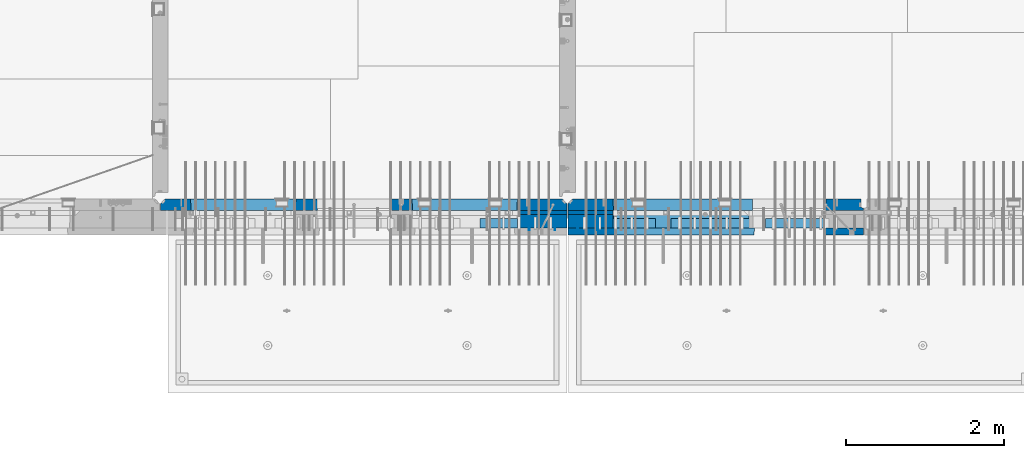
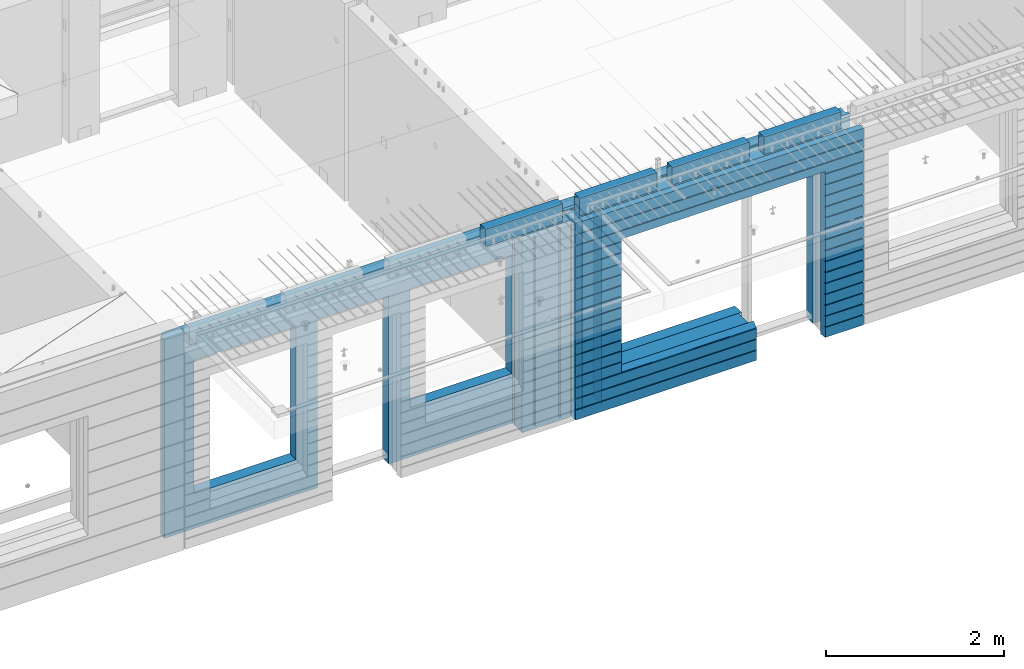
# One storey, part 221 of 334: 16 walls, 8 elements without a shape of their own.
"""IFC2X3 building model written with IfcOpenShell, lengths in millimetres."""

from ifc_helpers import new_model, si_unit, frame, origin_with_axes, place, context, subcontext, project, spatial, faceted_brep, material, type_object, element, aggregate, save


model = new_model("IFC2X3")

# Units and contexts
model_context = context("Model", 3, precision=1e-05, world=origin_with_axes())
body_context = subcontext(model_context, "Body", "Model", "MODEL_VIEW")
ifc_project = project(units=[si_unit("LENGTHUNIT", "METRE", prefix="MILLI"), si_unit("AREAUNIT", "SQUARE_METRE"), si_unit("VOLUMEUNIT", "CUBIC_METRE"), si_unit("MASSUNIT", "GRAM", prefix="KILO"), si_unit("TIMEUNIT", "SECOND"), si_unit("PLANEANGLEUNIT", "RADIAN"), si_unit("SOLIDANGLEUNIT", "STERADIAN"), si_unit("THERMODYNAMICTEMPERATUREUNIT", "DEGREE_CELSIUS"), si_unit("LUMINOUSINTENSITYUNIT", "LUMEN")], contexts=[model_context])

# Site, building, storey
site_placement = place(None, origin_with_axes())
site = spatial("IfcSite", under=ifc_project, at=site_placement, CompositionType="ELEMENT")
building_placement = place(site_placement, origin_with_axes())
building = spatial("IfcBuilding", under=site, at=building_placement, CompositionType="ELEMENT")
storey_placement = place(building_placement, origin_with_axes())
storey = spatial("IfcBuildingStorey", under=building, at=storey_placement, Name="3", CompositionType="ELEMENT", Elevation=0.0)

# Assembly, wall
assembly_1_placement = place(storey_placement, origin_with_axes())
assembly_1 = element("IfcElementAssembly", 1, at=assembly_1_placement, inside=storey, AssemblyPlace="NOTDEFINED", PredefinedType="REINFORCEMENT_UNIT")
ifc_material_1 = material(Name="Undefined")
wall_type_1 = type_object("IfcWallType", PredefinedType="NOTDEFINED")
wall_1_placement = place(assembly_1_placement, frame((21325.0, 7780.0, 89115.0), z_axis=(0.0, 0.0, 1.0), x_axis=(0.0, -1.0, 0.0)))
wall_1 = element("IfcWall", 2, at=wall_1_placement, type_object=wall_type_1, material=ifc_material_1, Name="(PD)", context=body_context, shape_type="Brep", body=[
    faceted_brep([(0.0, 5.0, -1300.0), (0.0, 5.0, 1300.0), (180.0, 5.0, 1300.0), (180.0, 5.0, -1300.0), (0.0, -5.0, 1300.0), (180.0, -5.0, 1300.0), (0.0, -5.0, -1300.0), (180.0, -5.0, -1300.0)], [[[0, 1, 2, 3]], [[1, 4, 5, 2]], [[4, 6, 7, 5]], [[6, 0, 3, 7]], [[5, 7, 3, 2]], [[6, 4, 1, 0]]]),
])

# Assembly, walls
assembly_2_placement = place(storey_placement, origin_with_axes())
assembly_2 = element("IfcElementAssembly", 3, at=assembly_2_placement, inside=storey, AssemblyPlace="NOTDEFINED", PredefinedType="REINFORCEMENT_UNIT")
wall_2_placement = place(assembly_2_placement, frame((22190.0, 7780.0, 89115.0), z_axis=(0.0, 0.0, 1.0), x_axis=(0.0, -1.0, 0.0)))
wall_2 = element("IfcWall", 4, at=wall_2_placement, type_object=wall_type_1, material=ifc_material_1, Name="(PD)", context=body_context, shape_type="Brep", body=[
    faceted_brep([(0.0, 5.0, -1300.0), (0.0, 5.0, 1300.0), (180.0, 5.0, 1300.0), (180.0, 5.0, -1300.0), (0.0, -5.0, 1300.0), (180.0, -5.0, 1300.0), (0.0, -5.0, -1300.0), (180.0, -5.0, -1300.0)], [[[0, 1, 2, 3]], [[1, 4, 5, 2]], [[4, 6, 7, 5]], [[6, 0, 3, 7]], [[5, 7, 3, 2]], [[6, 4, 1, 0]]]),
])
wall_3_placement = place(assembly_2_placement, frame((21940.0, 7780.0, 89115.0), z_axis=(0.0, 0.0, 1.0), x_axis=(0.0, -1.0, 0.0)))
wall_3 = element("IfcWall", 5, at=wall_3_placement, type_object=wall_type_1, material=ifc_material_1, Name="(PD)", context=body_context, shape_type="Brep", body=[
    faceted_brep([(0.0, 5.0, -1300.0), (0.0, 5.0, 1300.0), (180.0, 5.0, 1300.0), (180.0, 5.0, -1300.0), (0.0, -5.0, 1300.0), (180.0, -5.0, 1300.0), (0.0, -5.0, -1300.0), (180.0, -5.0, -1300.0)], [[[0, 1, 2, 3]], [[1, 4, 5, 2]], [[4, 6, 7, 5]], [[6, 0, 3, 7]], [[5, 7, 3, 2]], [[6, 4, 1, 0]]]),
])

# Wall
wall_4_placement = place(assembly_1_placement, frame((21650.0, 7780.0, 89115.0), z_axis=(0.0, 0.0, 1.0), x_axis=(0.0, -1.0, 0.0)))
wall_4 = element("IfcWall", 6, at=wall_4_placement, type_object=wall_type_1, material=ifc_material_1, Name="(PD)", context=body_context, shape_type="Brep", body=[
    faceted_brep([(0.0, 5.0, -1300.0), (0.0, 5.0, 1300.0), (180.0, 5.0, 1300.0), (180.0, 5.0, -1300.0), (0.0, -5.0, 1300.0), (180.0, -5.0, 1300.0), (0.0, -5.0, -1300.0), (180.0, -5.0, -1300.0)], [[[0, 1, 2, 3]], [[1, 4, 5, 2]], [[4, 6, 7, 5]], [[6, 0, 3, 7]], [[5, 7, 3, 2]], [[6, 4, 1, 0]]]),
])

# Assemblies, wall
assembly_3_placement = place(storey_placement, origin_with_axes())
assembly_3 = element("IfcElementAssembly", 7, at=assembly_3_placement, inside=storey, AssemblyPlace="NOTDEFINED", PredefinedType="REINFORCEMENT_UNIT")
assembly_4_placement = place(assembly_3_placement, origin_with_axes())
assembly_4 = element("IfcElementAssembly", 8, at=assembly_4_placement, Name="Steel Assembly", AssemblyPlace="NOTDEFINED", PredefinedType="NOTDEFINED")
aggregate(assembly_3, [assembly_4])
ifc_material_2 = material()
wall_type_2 = type_object("IfcWallType", PredefinedType="NOTDEFINED")
wall_5_placement = place(assembly_4_placement, frame((20699.9998568133, 7690.00021946163, 90590.0), z_axis=(0.0, 0.0, 1.0), x_axis=(1.0, 0.0, 0.0)))
wall_5 = element("IfcWall", 9, at=wall_5_placement, type_object=wall_type_2, material=ifc_material_2, context=body_context, shape_type="Brep", body=[
    faceted_brep([(0.0, 60.0, -120.0), (0.0, 60.0, 120.0), (1000.0, 60.0, 120.0), (1000.0, 60.0, -120.0), (0.0, -60.0, 120.0), (1000.0, -60.0, 120.0), (0.0, -60.0, -120.0), (1000.0, -60.0, -120.0)], [[[0, 1, 2, 3]], [[1, 4, 5, 2]], [[4, 6, 7, 5]], [[6, 0, 3, 7]], [[5, 7, 3, 2]], [[6, 4, 1, 0]]]),
])
aggregate(assembly_4, [wall_5])

# Assemblies, walls
assembly_5_placement = place(storey_placement, origin_with_axes())
assembly_5 = element("IfcElementAssembly", 10, at=assembly_5_placement, inside=storey, AssemblyPlace="NOTDEFINED", PredefinedType="REINFORCEMENT_UNIT")
assembly_6_placement = place(assembly_5_placement, origin_with_axes())
assembly_6 = element("IfcElementAssembly", 11, at=assembly_6_placement, Name="Steel Assembly", AssemblyPlace="NOTDEFINED", PredefinedType="NOTDEFINED")
wall_6_placement = place(assembly_6_placement, frame((24309.9998568133, 7690.00021946163, 90590.0), z_axis=(0.0, 0.0, 1.0), x_axis=(1.0, 0.0, 0.0)))
wall_6 = element("IfcWall", 12, at=wall_6_placement, type_object=wall_type_2, material=ifc_material_2, context=body_context, shape_type="Brep", body=[
    faceted_brep([(0.0, 60.0, -120.0), (0.0, 60.0, 120.0), (1000.0, 60.0, 120.0), (1000.0, 60.0, -120.0), (0.0, -60.0, 120.0), (1000.0, -60.0, 120.0), (0.0, -60.0, -120.0), (1000.0, -60.0, -120.0)], [[[0, 1, 2, 3]], [[1, 4, 5, 2]], [[4, 6, 7, 5]], [[6, 0, 3, 7]], [[5, 7, 3, 2]], [[6, 4, 1, 0]]]),
])
aggregate(assembly_6, [wall_6])
assembly_7_placement = place(assembly_5_placement, origin_with_axes())
assembly_7 = element("IfcElementAssembly", 13, at=assembly_7_placement, Name="Steel Assembly", AssemblyPlace="NOTDEFINED", PredefinedType="NOTDEFINED")
wall_7_placement = place(assembly_7_placement, frame((23119.9998568133, 7690.00021946163, 90590.0), z_axis=(0.0, 0.0, 1.0), x_axis=(1.0, 0.0, 0.0)))
wall_7 = element("IfcWall", 14, at=wall_7_placement, type_object=wall_type_2, material=ifc_material_2, context=body_context, shape_type="Brep", body=[
    faceted_brep([(0.0, 60.0, -120.0), (0.0, 60.0, 120.0), (1000.0, 60.0, 120.0), (1000.0, 60.0, -120.0), (0.0, -60.0, 120.0), (1000.0, -60.0, 120.0), (0.0, -60.0, -120.0), (1000.0, -60.0, -120.0)], [[[0, 1, 2, 3]], [[1, 4, 5, 2]], [[4, 6, 7, 5]], [[6, 0, 3, 7]], [[5, 7, 3, 2]], [[6, 4, 1, 0]]]),
])
aggregate(assembly_7, [wall_7])
assembly_8_placement = place(assembly_5_placement, origin_with_axes())
assembly_8 = element("IfcElementAssembly", 15, at=assembly_8_placement, Name="Steel Assembly", AssemblyPlace="NOTDEFINED", PredefinedType="NOTDEFINED")
aggregate(assembly_5, [assembly_8, assembly_7, assembly_6])
wall_8_placement = place(assembly_8_placement, frame((21919.9998568133, 7690.00021946163, 90590.0), z_axis=(0.0, 0.0, 1.0), x_axis=(1.0, 0.0, 0.0)))
wall_8 = element("IfcWall", 16, at=wall_8_placement, type_object=wall_type_2, material=ifc_material_2, context=body_context, shape_type="Brep", body=[
    faceted_brep([(0.0, 60.0, -120.0), (0.0, 60.0, 120.0), (1000.0, 60.0, 120.0), (1000.0, 60.0, -120.0), (0.0, -60.0, 120.0), (1000.0, -60.0, 120.0), (0.0, -60.0, -120.0), (1000.0, -60.0, -120.0)], [[[0, 1, 2, 3]], [[1, 4, 5, 2]], [[4, 6, 7, 5]], [[6, 0, 3, 7]], [[5, 7, 3, 2]], [[6, 4, 1, 0]]]),
])
aggregate(assembly_8, [wall_8])

# Wall
ifc_material_3 = material(Name="CONCRETE/C35/45")
wall_type_3 = type_object("IfcWallType", PredefinedType="NOTDEFINED")
wall_9_placement = place(assembly_2_placement, frame((25550.0, 7925.0, 89112.5), z_axis=(0.0, 0.0, 1.0), x_axis=(-1.0, 3.00000001838171e-08, 0.0)))
wall_9 = element("IfcWall", 17, at=wall_9_placement, type_object=wall_type_3, material=ifc_material_3, context=body_context, shape_type="Brep", body=[
    faceted_brep([(0.0, 75.0, 1357.5), (0.0, 75.0, -1357.5), (0.0, 45.0, -1357.5), (0.0, 45.0, 1357.5), (475.000517197066, -75.0, -1357.5), (478.846671043222, 75.0, -1357.5), (478.846671043219, 75.0, 948.653846153844), (475.000517197066, -75.0, 952.5), (32.5, -75.0, -1357.5), (32.5, 32.0, -1357.5), (32.5, -75.0, 1357.5), (32.5, 32.0, 1357.5), (3675.0, -75.0, 1357.5), (3735.0, -15.0, 1357.5), (3735.0, 75.0, 1357.5), (3735.0, 75.0, -1357.5), (3735.0, -15.0, -1357.5), (3675.0, -75.0, -1357.5), (1405.00051719707, -75.0, -1357.5), (1401.15436335091, 75.0, -1357.5), (1405.00051719707, -75.0, -882.5), (1401.15436335091, 75.0, -878.445945945947), (1334.05403802673, 75.0, 948.653846153844), (3160.9460816706, 75.0, -878.445945945947), (3160.9460816706, 75.0, 948.445945945947), (1401.15436335091, 75.0, 948.653846153844), (1330.00013572465, -75.0, 952.5), (1405.00051719707, -75.0, 952.5), (3165.00013572465, -75.0, -882.5), (3165.00013572465, -75.0, 952.5)], [[[0, 1, 2, 3]], [[4, 5, 6, 7]], [[8, 9, 2, 1, 5, 4]], [[10, 11, 9, 8]], [[3, 2, 9, 11]], [[10, 12, 13, 14, 0, 3, 11]], [[15, 14, 13, 16]], [[12, 17, 16, 13]], [[15, 16, 17, 18, 19]], [[19, 18, 20, 21]], [[22, 6, 5, 1, 0, 14, 15, 19, 21, 23, 24, 25]], [[26, 7, 6, 22, 25, 27]], [[28, 20, 18, 17, 12, 10, 8, 4, 7, 26, 27, 29]], [[25, 24, 29, 27]], [[23, 28, 29, 24]], [[21, 20, 28, 23]]]),
])

wall_10_placement = place(assembly_1_placement, frame((21810.0, 7925.0, 89112.5), z_axis=(0.0, 0.0, 1.0), x_axis=(-1.0, 3.00000001838171e-08, 0.0)))
wall_10 = element("IfcWall", 18, at=wall_10_placement, type_object=wall_type_3, material=ifc_material_3, context=body_context, shape_type="Brep", body=[
    faceted_brep([(5145.0, 75.0, -1357.5), (5145.0, -15.0, -1357.5), (5085.0, -75.0, -1357.5), (3165.00051719707, -75.0, -1357.5), (3161.15436335092, 75.0, -1357.5), (5085.0, -75.0, 1357.5), (5145.0, -15.0, 1357.5), (5145.0, 75.0, 1357.5), (10.0, 75.0, 1357.5), (10.0, -15.0, 1357.5), (70.0, -75.0, 1357.5), (10.0, -15.0, -1357.5), (70.0, -75.0, -1357.5), (10.0, 75.0, -1357.5), (2238.84667104322, 75.0, -1357.5), (2235.00051719707, -75.0, -1357.5), (2238.84667104322, 75.0, 948.653846153844), (2235.00051719707, -75.0, 952.5), (635.00013572734, -75.0, -682.5), (639.054189781393, 75.0, -678.445945945947), (639.054189781393, 75.0, 948.445945945947), (635.00013572734, -75.0, 952.5), (1965.00013572734, -75.0, -682.5), (1960.94608167329, 75.0, -678.445945945947), (1965.00013572734, -75.0, 952.5), (1960.94608167329, 75.0, 948.445945945947), (4764.99937278789, -75.0, -882.5), (4760.94531873383, 75.0, -878.445945945947), (3439.05342684194, 75.0, -878.445945945947), (3434.99937278789, -75.0, -882.5), (3165.00051719707, -75.0, 952.5), (3434.99937278789, -75.0, 952.5), (4764.99937278789, -75.0, 952.5), (4760.94531873383, 75.0, 948.445945945947), (3439.05342684194, 75.0, 948.445945945947), (3161.15436335092, 75.0, 948.653846153844)], [[[0, 1, 2, 3, 4]], [[5, 2, 1, 6]], [[0, 7, 6, 1]], [[5, 6, 7, 8, 9, 10]], [[9, 11, 12, 10]], [[8, 13, 11, 9]], [[12, 11, 13, 14, 15]], [[15, 14, 16, 17]], [[18, 19, 20, 21]], [[22, 23, 19, 18]], [[23, 22, 24, 25]], [[21, 20, 25, 24]], [[26, 27, 28, 29]], [[3, 2, 5, 10, 12, 15, 17, 30], [26, 29, 31, 32], [22, 18, 21, 24]], [[27, 26, 32, 33]], [[31, 34, 33, 32]], [[29, 28, 34, 31]], [[13, 8, 7, 0, 4, 35, 16, 14], [27, 33, 34, 28], [23, 25, 20, 19]], [[17, 16, 35, 30]], [[4, 3, 30, 35]]]),
])

wall_type_4 = type_object("IfcWallType", PredefinedType="NOTDEFINED")
wall_11_placement = place(assembly_1_placement, frame((21800.0000381475, 7825.0, 89112.5), z_axis=(0.0, 0.0, 1.0), x_axis=(-1.0, 3.00000001838171e-08, 0.0)))
wall_11 = element("IfcWall", 19, at=wall_11_placement, type_object=wall_type_4, material=ifc_material_3, context=body_context, shape_type="Brep", body=[
    faceted_brep([(0.0, 25.0, -1357.5), (0.0, 25.0, 1357.5), (625.001908754726, 25.0, 1357.5), (625.001908754726, 25.0, -1357.5), (0.0, -25.0, 1357.5), (625.001908754726, -25.0, 1357.5), (0.0, -25.0, -1357.5), (625.001908754726, -25.0, -1357.5)], [[[0, 1, 2, 3]], [[1, 4, 5, 2]], [[4, 6, 7, 5]], [[6, 0, 3, 7]], [[5, 7, 3, 2]], [[6, 4, 1, 0]]]),
])

wall_12_placement = place(assembly_2_placement, frame((22385.0000381475, 7825.00011629906, 89112.5), z_axis=(0.0, 0.0, 1.0), x_axis=(-1.0, 3.00000001838171e-08, 0.0)))
wall_12 = element("IfcWall", 20, at=wall_12_placement, type_object=wall_type_4, material=ifc_material_3, context=body_context, shape_type="Brep", body=[
    faceted_brep([(0.0, 25.0, -1357.5), (0.0, 25.0, 1357.5), (570.001908754726, 25.0, 1357.5), (570.001908754726, 25.0, -1357.5), (0.0, -25.0, 1357.5), (570.001908754726, -25.0, 1357.5), (0.0, -25.0, -1357.5), (570.001908754726, -25.0, -1357.5)], [[[0, 1, 2, 3]], [[1, 4, 5, 2]], [[4, 6, 7, 5]], [[6, 0, 3, 7]], [[5, 7, 3, 2]], [[6, 4, 1, 0]]]),
])

ifc_material_4 = material(Name="SPU")
wall_type_5 = type_object("IfcWallType", PredefinedType="NOTDEFINED")
wall_13_placement = place(assembly_1_placement, frame((21800.0000381475, 7715.0, 89102.5), z_axis=(0.0, 0.0, 1.0), x_axis=(-1.0, 3.00000001838171e-08, 0.0)))
wall_13 = element("IfcWall", 21, at=wall_13_placement, type_object=wall_type_5, material=ifc_material_4, context=body_context, shape_type="Brep", body=[
    faceted_brep([(0.0, 85.0, -1347.5), (0.0, 85.0, 1347.5), (625.001908754726, 85.0, 1347.5), (625.001908754726, 85.0, -1347.5), (0.0, -85.0, 1347.5), (625.001908754726, -85.0, 1347.5), (0.0, -85.0, -1347.5), (625.001908754726, -85.0, -1347.5)], [[[0, 1, 2, 3]], [[1, 4, 5, 2]], [[4, 6, 7, 5]], [[6, 0, 3, 7]], [[5, 7, 3, 2]], [[6, 4, 1, 0]]]),
])

aggregate(assembly_1, [wall_13, wall_11, wall_1, wall_4, wall_10])

wall_14_placement = place(assembly_2_placement, frame((22385.0000381475, 7715.00011629906, 89102.5), z_axis=(0.0, 0.0, 1.0), x_axis=(-1.0, 3.00000001838171e-08, 0.0)))
wall_14 = element("IfcWall", 22, at=wall_14_placement, type_object=wall_type_5, material=ifc_material_4, context=body_context, shape_type="Brep", body=[
    faceted_brep([(0.0, 85.0, -1347.5), (0.0, 85.0, 1347.5), (570.001908754726, 85.0, 1347.5), (570.001908754726, 85.0, -1347.5), (0.0, -85.0, 1347.5), (570.001908754726, -85.0, 1347.5), (0.0, -85.0, -1347.5), (570.001908754726, -85.0, -1347.5)], [[[0, 1, 2, 3]], [[1, 4, 5, 2]], [[4, 6, 7, 5]], [[6, 0, 3, 7]], [[5, 7, 3, 2]], [[6, 4, 1, 0]]]),
])

ifc_material_5 = material(Name="CONCRETE/C30/37")
wall_type_6 = type_object("IfcWallType", PredefinedType="NOTDEFINED")
wall_15_placement = place(assembly_2_placement, frame((25550.0, 7587.5, 89102.5), z_axis=(0.0, 0.0, 1.0), x_axis=(-1.0, 3.00000001838171e-08, 0.0)))
wall_15 = element("IfcWall", 23, at=wall_15_placement, type_object=wall_type_6, material=ifc_material_5, context=body_context, shape_type="Brep", body=[
    faceted_brep([(3135.00013572465, 42.5, -912.000000055254), (3135.00013572465, 42.5, -912.5), (3134.8486205936, 41.2121213860491, -911.742424344731), (3735.0, 32.4999991126861, -1049.99999959956), (3735.0, 32.4999992506973, -1060.00000000076), (1383.82179161871, 32.4999992506973, -1060.00000000076), (1383.82179160247, 32.4999991126861, -1049.99999959956), (3735.0, 42.5, -1062.00000005522), (1384.99845837354, 42.5, -1062.00000005522), (3735.0, 42.5, -1198.00000011075), (1384.99845837354, 42.5, -1198.00000011075), (3735.0, 32.4999991121604, -1199.99999959957), (1383.8217916024, 32.4999991121604, -1199.99999959957), (3735.0, 32.4999992501671, -1210.00000000079), (1383.82179161864, 32.4999992501671, -1210.00000000079), (3735.0, 42.5, -1212.00000005524), (1384.99845837354, 42.5, -1212.00000005524), (3735.0, 42.5, -1347.5), (1384.99845837354, 42.5, -1347.5), (3735.0, -42.5, -1347.5), (1374.99679170687, -42.5, -1347.5), (3.63797880709171e-12, 32.4999992499725, 1039.99999999921), (3735.0, 32.4999992499725, 1039.99999999921), (3735.0, 42.5, 1037.99999994476), (0.0, 42.5, 1037.99999994476), (3.63797880709171e-12, 32.4999991119639, 1050.00000040043), (3735.0, 32.4999991119639, 1050.00000040043), (0.0, 42.5, 1051.99999988925), (3735.0, 42.5, 1051.99999988925), (0.0, 42.5, 1187.99999994476), (3735.0, 42.5, 1187.99999994476), (-3.63797880709171e-12, 32.499999249967, 1189.99999999923), (3735.0, 32.499999249967, 1189.99999999923), (-3.63797880709171e-12, 32.4999991119576, 1200.00000040043), (3735.0, 32.4999991119576, 1200.00000040043), (0.0, 42.5, 1201.99999988925), (3735.0, 42.5, 1201.99999988925), (0.0, 42.5, 1347.5), (3735.0, 42.5, 1347.5), (0.0, -42.5, 1347.5), (3735.0, -42.5, 1347.5), (3125.00013572465, -42.5, 927.5), (3125.00013572465, -42.5, -862.5), (1374.99679170687, -42.5, -862.5), (0.0, -42.5, -1347.5), (505.000125040202, -42.5, -1347.5), (505.000125040206, -42.5, 927.5), (505.000125040206, -42.5, 932.502857142856), (1370.00013572465, -42.5, 932.502857142856), (1374.99679170687, -42.5, 932.5), (3125.00013572465, -42.5, 932.5), (0.0, 42.5, -1347.5), (494.998458373539, 42.5, -1347.5), (0.0, 42.5, -1212.00000005524), (494.998458373539, 42.5, -1212.00000005524), (0.0, 32.4999992501671, -1210.00000000079), (496.175125128437, 32.4999992501671, -1210.00000000079), (0.0, 32.4999991121604, -1199.99999959957), (496.175125144673, 32.4999991121604, -1199.99999959957), (0.0, 42.5, -1198.00000011075), (494.998458373539, 42.5, -1198.00000011075), (0.0, 42.5, -1062.00000005522), (494.998458373539, 42.5, -1062.00000005522), (0.0, 32.4999992506973, -1060.00000000076), (496.175125128375, 32.4999992506973, -1060.00000000076), (0.0, 32.4999991126861, -1049.99999959956), (496.175125144611, 32.4999991126861, -1049.99999959956), (0.0, 42.5, -1048.00000011074), (494.998458373539, 42.5, -1048.00000011074), (0.0, 42.5, -912.000000055254), (494.998458373539, 42.5, -912.000000055254), (0.0, 32.4999992512376, -910.000000000786), (496.175125128309, 32.4999992512376, -910.000000000786), (0.0, 32.499999113239, -899.99999959959), (496.175125144546, 32.499999113239, -899.99999959959), (0.0, 42.5, -898.000000110769), (494.998458373539, 42.5, -898.000000110769), (0.0, 42.5, -762.000000055225), (494.998458373539, 42.5, -762.000000055225), (0.0, 32.4999992517696, -760.000000000757), (496.175125128244, 32.4999992517696, -760.000000000757), (0.0, 32.4999991137702, -749.99999959956), (496.175125144484, 32.4999991137702, -749.99999959956), (0.0, 42.5, -748.00000011074), (494.998458373539, 42.5, -748.00000011074), (0.0, 42.5, -612.000000055239), (494.998458373539, 42.5, -612.000000055239), (0.0, 32.4999992522971, -610.000000000771), (496.175125128182, 32.4999992522971, -610.000000000771), (0.0, 32.4999991143004, -599.99999959956), (496.175125144422, 32.4999991143004, -599.99999959956), (0.0, 42.5, -598.000000110755), (494.998458373539, 42.5, -598.000000110755), (0.0, 42.5, -462.000000055239), (494.998458373539, 42.5, -462.000000055239), (0.0, 32.4999992528365, -460.000000000771), (496.17512512812, 32.4999992528365, -460.000000000771), (0.0, 32.4999991148252, -449.999999599575), (496.17512514436, 32.4999991148252, -449.999999599575), (0.0, 42.5, -448.000000110755), (494.998458373539, 42.5, -448.000000110755), (0.0, 42.5, -312.000000055254), (494.998458373539, 42.5, -312.000000055254), (0.0, 32.4999992533649, -310.000000000786), (496.175125128058, 32.4999992533649, -310.000000000786), (0.0, 32.4999991153618, -299.99999959959), (496.175125144298, 32.4999991153618, -299.99999959959), (0.0, 42.5, -298.000000110769), (494.998458373539, 42.5, -298.000000110769), (0.0, 42.5, -162.000000055239), (494.998458373539, 42.5, -162.000000055239), (0.0, 32.4999992538978, -160.000000000757), (496.175125127997, 32.4999992538978, -160.000000000757), (0.0, 32.4999991158993, -149.99999959956), (496.175125144237, 32.4999991158993, -149.99999959956), (0.0, 42.5, -148.000000110755), (494.998458373539, 42.5, -148.000000110755), (0.0, 42.5, -12.0000000552391), (494.998458373539, 42.5, -12.0000000552391), (0.0, 32.4999992538942, -10.0000000007858), (496.175125127997, 32.4999992538942, -10.0000000007858), (3.63797880709171e-12, 32.4999992499852, 889.999999999229), (3.63797880709171e-12, 32.4999991119857, 900.000000400425), (496.175125144691, 32.4999991119857, 900.000000400425), (496.175125128459, 32.4999992499852, 889.999999999229), (0.0, 42.5, 887.999999944761), (494.998458373539, 42.5, 887.999999944761), (0.0, 42.5, 751.999999889245), (494.998458373539, 42.5, 751.999999889245), (0.0, 32.4999991120039, 750.00000040044), (496.175125144691, 32.4999991120039, 750.00000040044), (0.0, 32.4999992499997, 739.999999999229), (496.175125128455, 32.4999992499997, 739.999999999229), (0.0, 42.5, 737.999999944761), (494.998458373539, 42.5, 737.999999944761), (0.0, 42.5, 601.99999988926), (494.998458373539, 42.5, 601.99999988926), (0.0, 32.4999991120094, 600.00000040044), (496.175125144691, 32.4999991120094, 600.00000040044), (0.0, 32.499999250017, 589.999999999229), (496.175125128455, 32.499999250017, 589.999999999229), (0.0, 42.5, 587.999999944775), (494.998458373539, 42.5, 587.999999944775), (0.0, 42.5, 451.999999889231), (494.998458373539, 42.5, 451.999999889231), (0.0, 32.4999991120258, 450.000000400411), (496.175125144688, 32.4999991120258, 450.000000400411), (0.0, 32.4999992500289, 439.999999999214), (496.175125128451, 32.4999992500289, 439.999999999214), (0.0, 42.5, 437.999999944746), (494.998458373539, 42.5, 437.999999944746), (0.0, 42.5, 301.999999889245), (494.998458373539, 42.5, 301.999999889245), (-3.63797880709171e-12, 32.4999991120458, 300.00000040044), (496.175125144688, 32.4999991120458, 300.00000040044), (-3.63797880709171e-12, 32.4999992500416, 289.999999999229), (496.175125128451, 32.4999992500416, 289.999999999229), (0.0, 42.5, 287.999999944761), (494.998458373539, 42.5, 287.999999944761), (0.0, 42.5, 151.99999988926), (494.998458373539, 42.5, 151.99999988926), (0.0, 32.4999991120549, 150.00000040044), (496.175125144684, 32.4999991120549, 150.00000040044), (0.0, 32.4999992500552, 139.999999999229), (496.175125128448, 32.4999992500552, 139.999999999229), (0.0, 42.5, 137.999999944775), (494.998458373539, 42.5, 137.999999944775), (0.0, 42.5, 1.99999988924537), (494.998458373539, 42.5, 1.99999988924537), (0.0, 32.4999991158911, 4.00425051338971e-07), (496.175125144237, 32.4999991158911, 4.00425051338971e-07), (0.0, 42.5, 901.999999889245), (494.998458373539, 42.5, 901.999999889245), (494.998458373539, 42.5, 927.5), (505.000517197066, 42.5, 927.5), (1360.00013572465, 42.5, 927.5), (1370.00013572465, 42.5, 927.5), (1375.00051719707, 42.5, 927.5), (1384.99845837354, 42.5, 927.5), (3125.00013572465, 42.5, 927.5), (3135.00013572465, 42.5, 927.5), (3735.0, 42.5, 901.999999889245), (3135.00013572465, 42.5, 901.999999889245), (3735.0, 32.4999991119857, 900.000000400425), (3133.82366503195, 32.4999991119857, 900.000000400425), (3735.0, 32.4999992499852, 889.999999999229), (3133.82366504818, 32.4999992499852, 889.999999999229), (3735.0, 42.5, 887.999999944761), (3135.00013572465, 42.5, 887.999999944761), (3735.0, 42.5, 751.999999889245), (3135.00013572465, 42.5, 751.999999889245), (3735.0, 32.4999991120039, 750.00000040044), (3133.82366503195, 32.4999991120039, 750.00000040044), (3735.0, 32.4999992499997, 739.999999999229), (3133.82366504818, 32.4999992499997, 739.999999999229), (3735.0, 42.5, 737.999999944761), (3135.00013572465, 42.5, 737.999999944761), (3735.0, 42.5, 601.99999988926), (3135.00013572465, 42.5, 601.99999988926), (3735.0, 32.4999991120094, 600.00000040044), (3133.82366503195, 32.4999991120094, 600.00000040044), (3735.0, 32.499999250017, 589.999999999229), (3133.82366504818, 32.499999250017, 589.999999999229), (3735.0, 42.5, 587.999999944775), (3135.00013572465, 42.5, 587.999999944775), (3735.0, 42.5, 451.999999889231), (3135.00013572465, 42.5, 451.999999889231), (3735.0, 32.4999991120258, 450.000000400411), (3133.82366503195, 32.4999991120258, 450.000000400411), (3735.0, 32.4999992500289, 439.999999999214), (3133.82366504818, 32.4999992500289, 439.999999999214), (3735.0, 42.5, 437.999999944746), (3135.00013572465, 42.5, 437.999999944746), (3735.0, 42.5, 301.999999889245), (3135.00013572465, 42.5, 301.999999889245), (3735.0, 32.4999991120458, 300.00000040044), (3133.82366503195, 32.4999991120458, 300.00000040044), (3735.0, 32.4999992500416, 289.999999999229), (3133.82366504819, 32.4999992500416, 289.999999999229), (3735.0, 42.5, 287.999999944761), (3135.00013572465, 42.5, 287.999999944761), (3735.0, 42.5, 151.99999988926), (3135.00013572465, 42.5, 151.99999988926), (3735.0, 32.4999991120549, 150.00000040044), (3133.82366503195, 32.4999991120549, 150.00000040044), (3735.0, 32.4999992500552, 139.999999999229), (3133.82366504819, 32.4999992500552, 139.999999999229), (3735.0, 42.5, 137.999999944775), (3135.00013572465, 42.5, 137.999999944775), (3735.0, 42.5, 1.99999988924537), (3135.00013572465, 42.5, 1.99999988924537), (3735.0, 32.4999991158911, 4.00425051338971e-07), (3735.0, 32.4999992538942, -10.0000000007858), (3133.82366504864, 32.4999992538942, -10.0000000007858), (3133.8236650324, 32.4999991158911, 4.00425051338971e-07), (3735.0, 42.5, -12.0000000552391), (3135.00013572465, 42.5, -12.0000000552391), (3735.0, 42.5, -148.000000110755), (3135.00013572465, 42.5, -148.000000110755), (3735.0, 32.4999991158993, -149.99999959956), (3133.8236650324, 32.4999991158993, -149.99999959956), (3735.0, 32.4999992538978, -160.000000000757), (3133.82366504864, 32.4999992538978, -160.000000000757), (3735.0, 42.5, -162.000000055239), (3135.00013572465, 42.5, -162.000000055239), (3735.0, 42.5, -298.000000110769), (3135.00013572465, 42.5, -298.000000110769), (3735.0, 32.4999991153618, -299.99999959959), (3133.82366503234, 32.4999991153618, -299.99999959959), (3735.0, 32.4999992533649, -310.000000000786), (3133.82366504858, 32.4999992533649, -310.000000000786), (3735.0, 42.5, -312.000000055254), (3135.00013572465, 42.5, -312.000000055254), (3735.0, 42.5, -448.000000110755), (3135.00013572465, 42.5, -448.000000110755), (3735.0, 32.4999991148252, -449.999999599575), (3133.82366503228, 32.4999991148252, -449.999999599575), (3735.0, 32.4999992528365, -460.000000000771), (3133.82366504852, 32.4999992528365, -460.000000000771), (3735.0, 42.5, -462.000000055239), (3135.00013572465, 42.5, -462.000000055239), (3735.0, 42.5, -598.000000110755), (3135.00013572465, 42.5, -598.000000110755), (3735.0, 32.4999991143004, -599.99999959956), (3133.82366503222, 32.4999991143004, -599.99999959956), (3735.0, 32.4999992522971, -610.000000000771), (3133.82366504845, 32.4999992522971, -610.000000000771), (3735.0, 42.5, -612.000000055239), (3135.00013572465, 42.5, -612.000000055239), (3735.0, 42.5, -748.00000011074), (3135.00013572465, 42.5, -748.00000011074), (3735.0, 32.4999991137702, -749.99999959956), (3133.82366503216, 32.4999991137702, -749.99999959956), (3735.0, 32.4999992517696, -760.000000000757), (3133.82366504839, 32.4999992517696, -760.000000000757), (3735.0, 42.5, -762.000000055225), (3135.00013572465, 42.5, -762.000000055225), (3735.0, 42.5, -898.000000110769), (3135.00013572465, 42.5, -898.000000110769), (3735.0, 32.499999113239, -899.99999959959), (3133.82366503209, 32.499999113239, -899.99999959959), (3133.82366504284, 32.4999992045623, -906.617646590923), (3735.0, 42.5, -1048.00000011074), (3735.0, 42.5, -912.000000055254), (3735.0, 32.4999992512376, -910.000000000786), (1384.99845837354, 42.5, -1048.00000011074), (1384.99845837354, 42.5, -912.5), (1384.84691798997, 41.2121213860719, -911.742424344746), (1383.82179161877, 32.4999992512376, -910.000000000786), (1383.82179161327, 32.4999992045614, -906.617646590908)], [[[0, 1, 2]], [[3, 4, 5, 6]], [[4, 7, 8, 5]], [[7, 9, 10, 8]], [[9, 11, 12, 10]], [[11, 13, 14, 12]], [[13, 15, 16, 14]], [[15, 17, 18, 16]], [[17, 19, 20, 18]], [[21, 22, 23, 24]], [[25, 26, 22, 21]], [[27, 28, 26, 25]], [[28, 27, 29, 30]], [[31, 32, 30, 29]], [[33, 34, 32, 31]], [[35, 36, 34, 33]], [[37, 38, 36, 35]], [[37, 39, 40, 38]], [[41, 42, 43, 20, 19, 40, 39, 44, 45, 46, 47, 48, 49, 50]], [[44, 51, 52, 45]], [[51, 53, 54, 52]], [[53, 55, 56, 54]], [[55, 57, 58, 56]], [[57, 59, 60, 58]], [[59, 61, 62, 60]], [[61, 63, 64, 62]], [[63, 65, 66, 64]], [[65, 67, 68, 66]], [[67, 69, 70, 68]], [[69, 71, 72, 70]], [[71, 73, 74, 72]], [[73, 75, 76, 74]], [[75, 77, 78, 76]], [[77, 79, 80, 78]], [[79, 81, 82, 80]], [[81, 83, 84, 82]], [[83, 85, 86, 84]], [[85, 87, 88, 86]], [[87, 89, 90, 88]], [[89, 91, 92, 90]], [[91, 93, 94, 92]], [[93, 95, 96, 94]], [[95, 97, 98, 96]], [[97, 99, 100, 98]], [[99, 101, 102, 100]], [[101, 103, 104, 102]], [[103, 105, 106, 104]], [[105, 107, 108, 106]], [[107, 109, 110, 108]], [[109, 111, 112, 110]], [[111, 113, 114, 112]], [[113, 115, 116, 114]], [[115, 117, 118, 116]], [[117, 119, 120, 118]], [[121, 122, 123, 124]], [[125, 121, 124, 126]], [[127, 125, 126, 128]], [[129, 127, 128, 130]], [[131, 129, 130, 132]], [[133, 131, 132, 134]], [[135, 133, 134, 136]], [[137, 135, 136, 138]], [[139, 137, 138, 140]], [[141, 139, 140, 142]], [[143, 141, 142, 144]], [[145, 143, 144, 146]], [[147, 145, 146, 148]], [[149, 147, 148, 150]], [[151, 149, 150, 152]], [[153, 151, 152, 154]], [[155, 153, 154, 156]], [[157, 155, 156, 158]], [[159, 157, 158, 160]], [[161, 159, 160, 162]], [[163, 161, 162, 164]], [[165, 163, 164, 166]], [[167, 165, 166, 168]], [[169, 167, 168, 170]], [[119, 169, 170, 120]], [[117, 115, 113, 111, 109, 107, 105, 103, 101, 99, 97, 95, 93, 91, 89, 87, 85, 83, 81, 79, 77, 75, 73, 71, 69, 67, 65, 63, 61, 59, 57, 55, 53, 51, 44, 39, 37, 35, 33, 31, 29, 27, 25, 21, 24, 171, 122, 121, 125, 127, 129, 131, 133, 135, 137, 139, 141, 143, 145, 147, 149, 151, 153, 155, 157, 159, 161, 163, 165, 167, 169, 119]], [[122, 171, 172, 123]], [[173, 47, 46, 45, 52, 54, 56, 58, 60, 62, 64, 66, 68, 70, 72, 74, 76, 78, 80, 82, 84, 86, 88, 90, 92, 94, 96, 98, 100, 102, 104, 106, 108, 110, 112, 114, 116, 118, 120, 170, 168, 166, 164, 162, 160, 158, 156, 154, 152, 150, 148, 146, 144, 142, 140, 138, 136, 134, 132, 130, 128, 126, 124, 123, 172]], [[174, 175, 176, 177, 178, 49, 48, 47, 173]], [[49, 178, 179, 180, 50]], [[178, 177, 176, 175, 174, 173, 172, 171, 24, 23, 181, 182, 180, 179]], [[181, 183, 184, 182]], [[183, 185, 186, 184]], [[185, 187, 188, 186]], [[187, 189, 190, 188]], [[189, 191, 192, 190]], [[191, 193, 194, 192]], [[193, 195, 196, 194]], [[195, 197, 198, 196]], [[197, 199, 200, 198]], [[199, 201, 202, 200]], [[201, 203, 204, 202]], [[203, 205, 206, 204]], [[205, 207, 208, 206]], [[207, 209, 210, 208]], [[209, 211, 212, 210]], [[211, 213, 214, 212]], [[213, 215, 216, 214]], [[215, 217, 218, 216]], [[217, 219, 220, 218]], [[219, 221, 222, 220]], [[221, 223, 224, 222]], [[223, 225, 226, 224]], [[225, 227, 228, 226]], [[227, 229, 230, 228]], [[231, 232, 233, 234]], [[232, 235, 236, 233]], [[235, 237, 238, 236]], [[237, 239, 240, 238]], [[239, 241, 242, 240]], [[241, 243, 244, 242]], [[243, 245, 246, 244]], [[245, 247, 248, 246]], [[247, 249, 250, 248]], [[249, 251, 252, 250]], [[251, 253, 254, 252]], [[253, 255, 256, 254]], [[255, 257, 258, 256]], [[257, 259, 260, 258]], [[259, 261, 262, 260]], [[261, 263, 264, 262]], [[263, 265, 266, 264]], [[265, 267, 268, 266]], [[267, 269, 270, 268]], [[269, 271, 272, 270]], [[271, 273, 274, 272]], [[273, 275, 276, 274]], [[275, 277, 278, 276]], [[277, 279, 280, 278]], [[41, 50, 180, 182, 184, 186, 188, 190, 192, 194, 196, 198, 200, 202, 204, 206, 208, 210, 212, 214, 216, 218, 220, 222, 224, 226, 228, 230, 234, 233, 236, 238, 240, 242, 244, 246, 248, 250, 252, 254, 256, 258, 260, 262, 264, 266, 268, 270, 272, 274, 276, 278, 280, 281, 42]], [[229, 231, 234, 230]], [[227, 225, 223, 221, 219, 217, 215, 213, 211, 209, 207, 205, 203, 201, 199, 197, 195, 193, 191, 189, 187, 185, 183, 181, 23, 22, 26, 28, 30, 32, 34, 36, 38, 40, 19, 17, 15, 13, 11, 9, 7, 4, 3, 282, 283, 284, 279, 277, 275, 273, 271, 269, 267, 265, 263, 261, 259, 257, 255, 253, 251, 249, 247, 245, 243, 241, 239, 237, 235, 232, 231, 229]], [[0, 283, 282, 285, 286, 1]], [[287, 2, 1, 286]], [[288, 284, 283, 0, 2, 287]], [[280, 279, 284, 288, 289, 281]], [[43, 42, 281, 289]], [[288, 287, 286, 285, 6, 5, 8, 10, 12, 14, 16, 18, 20, 43, 289]], [[282, 3, 6, 285]]]),
])

ifc_material_6 = material(Name="COS5gt")
wall_type_7 = type_object("IfcWallType", PredefinedType="NOTDEFINED")
wall_16_placement = place(assembly_2_placement, frame((25075.0, 7740.0, 89102.5), z_axis=(0.0, 0.0, 1.0), x_axis=(-1.0, 3.00000001838171e-08, 0.0)))
wall_16 = element("IfcWall", 24, at=wall_16_placement, type_object=wall_type_7, material=ifc_material_6, context=body_context, shape_type="Brep", body=[
    faceted_brep([(2690.0, 90.0, -1297.5), (2690.0, 90.0, -1347.5), (970.000517197066, 90.0, -1347.5), (970.000517197066, 90.0, -1297.5), (2690.0, 110.0, -1297.5), (970.000517197066, 110.0, -1297.5), (2690.0, 110.0, 1347.5), (2690.0, -110.0, 1347.5), (2690.0, -110.0, -1347.5), (0.0, 110.0, 1347.5), (0.0, -110.0, 1347.5), (0.0, 110.0, 1002.5), (0.0, -110.0, 1002.5), (970.000517197066, 110.0, 1002.5), (970.000517197066, -110.0, 1002.5), (970.000517197066, 110.0, 952.5), (970.000517197066, -110.0, 958.445945945947), (2685.9460816706, -110.000000000001, -868.445945945947), (970.000517197066, -110.0, -868.445945945947), (970.000517197066, -110.0, -1347.5), (2685.9460816706, -110.0, 958.445945945947), (2680.00013572465, 110.0, -857.5), (2680.00013572465, 110.0, -862.5), (2680.00013572465, 110.0, 952.5), (970.000517197066, 110.0, -862.5), (2650.00013572465, 110.0, -862.5)], [[[0, 1, 2, 3]], [[4, 0, 3, 5]], [[6, 7, 8, 1, 0, 4]], [[9, 10, 7, 6]], [[10, 9, 11, 12]], [[12, 11, 13, 14]], [[14, 13, 15, 16]], [[17, 18, 19, 8, 7, 10, 12, 14, 16, 20]], [[21, 22, 17, 20, 23]], [[16, 15, 23, 20]], [[13, 11, 9, 6, 4, 5, 24, 25, 22, 21, 23, 15]], [[18, 17, 22, 25, 24]], [[5, 3, 2, 19, 18, 24]], [[1, 8, 19, 2]]]),
])

aggregate(assembly_2, [wall_14, wall_12, wall_2, wall_3, wall_15, wall_16, wall_9])

save(model, "model.ifc")
